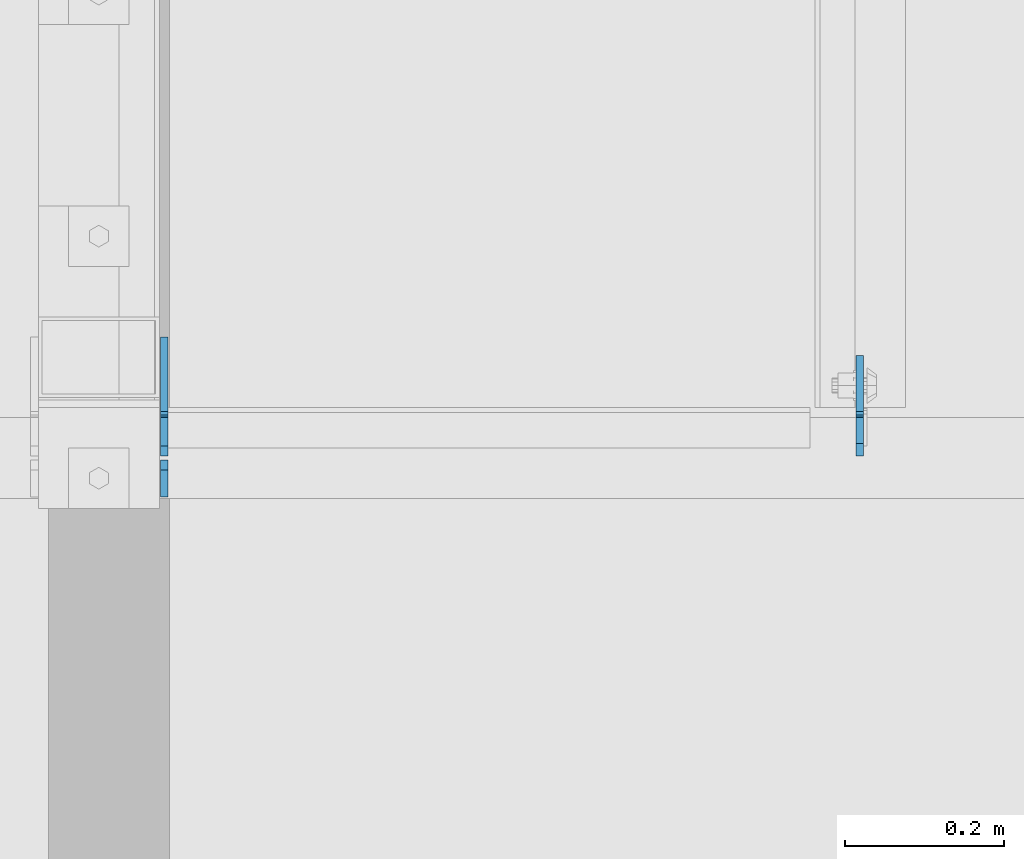
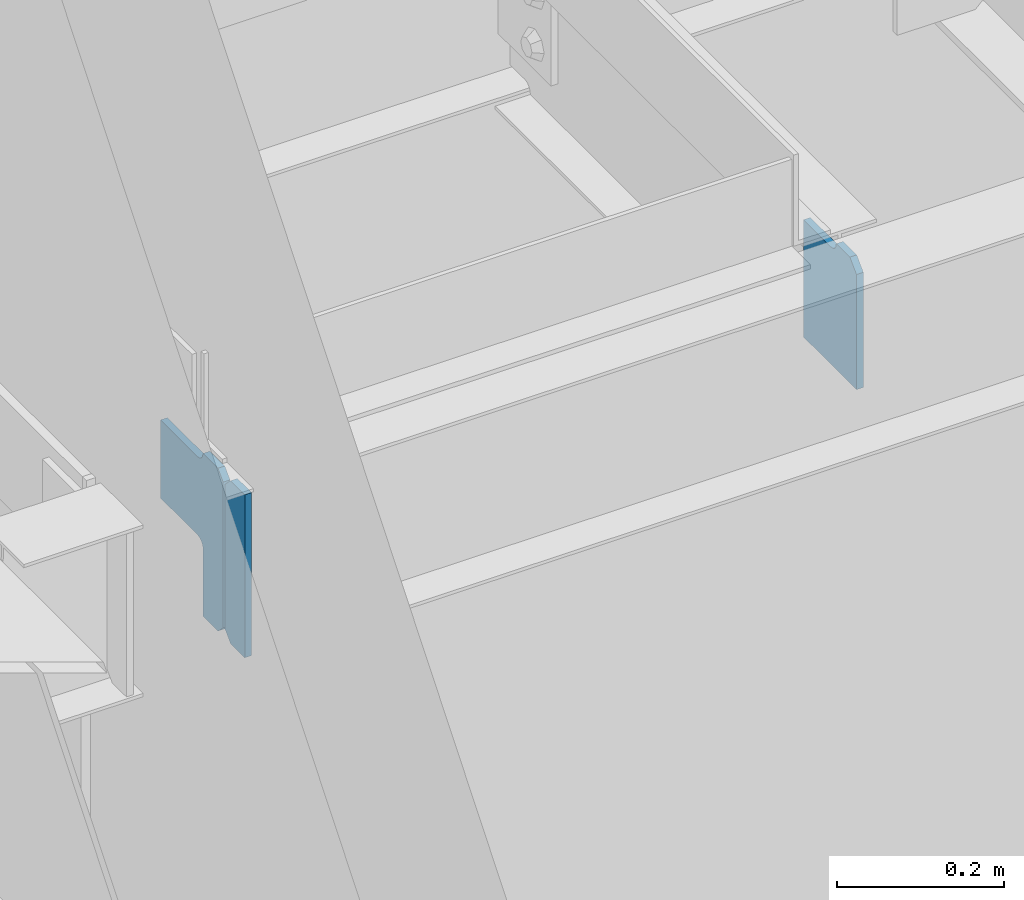
# One storey, part 1108 of 1179: 3 plates, 2 elements without a shape of their own.
"""IFC2X3 building model written with IfcOpenShell, lengths in millimetres."""

from ifc_helpers import new_model, si_unit, frame, origin_with_axes, place, context, subcontext, project, spatial, faceted_brep, material, type_object, element, aggregate, save


model = new_model("IFC2X3")

# Units and contexts
model_context = context("Model", 3, precision=1e-05, world=origin_with_axes())
body_context = subcontext(model_context, "Body", "Model", "MODEL_VIEW")
ifc_project = project(units=[si_unit("LENGTHUNIT", "METRE", prefix="MILLI"), si_unit("AREAUNIT", "SQUARE_METRE"), si_unit("VOLUMEUNIT", "CUBIC_METRE"), si_unit("MASSUNIT", "GRAM", prefix="KILO"), si_unit("TIMEUNIT", "SECOND"), si_unit("PLANEANGLEUNIT", "RADIAN"), si_unit("SOLIDANGLEUNIT", "STERADIAN"), si_unit("THERMODYNAMICTEMPERATUREUNIT", "DEGREE_CELSIUS"), si_unit("LUMINOUSINTENSITYUNIT", "LUMEN")], contexts=[model_context])

# Site, building, storey
site_placement = place(None, origin_with_axes())
site = spatial("IfcSite", under=ifc_project, at=site_placement, CompositionType="ELEMENT")
building_placement = place(site_placement, origin_with_axes())
building = spatial("IfcBuilding", under=site, at=building_placement, Name="Undefined", CompositionType="ELEMENT")
storey_placement = place(building_placement, origin_with_axes())
storey = spatial("IfcBuildingStorey", under=building, at=storey_placement, Name="Undefined", CompositionType="ELEMENT", Elevation=0.0)

# Assembly, plates
assembly_1_placement = place(storey_placement, origin_with_axes())
assembly_1 = element("IfcElementAssembly", 1, at=assembly_1_placement, inside=storey, Name="BEAM", AssemblyPlace="NOTDEFINED", PredefinedType="RIGID_FRAME")
ifc_material = material(Name="STEEL/A36")
plate_type_1 = type_object("IfcPlateType", PredefinedType="NOTDEFINED")
plate_1_placement = place(assembly_1_placement, frame((17734.7557500839, 39981.98125, 12928.6), z_axis=(0.0, 0.0, 1.0), x_axis=(0.0, 1.0, 0.0)))
plate_1 = element("IfcPlate", 2, at=plate_1_placement, type_object=plate_type_1, material=ifc_material, Name="PLATE", context=body_context, shape_type="Brep", body=[
    faceted_brep([(15.875, -4.76250000000073, 184.15), (15.875, 4.76250000000073, 184.15), (0.0, 4.76250000000073, 168.275), (0.0, -4.76250000000073, 168.275), (127.0, -4.76250000000073, 0.0), (0.0, -4.76249999999709, 0.0), (0.0, 4.76249999999709, 0.0), (127.0, 4.76250000000073, 0.0), (127.0, 4.76250000000073, 171.449999999999), (127.0, -4.76250000000073, 171.449999999999), (61.1187498092695, 4.76250000000073, 171.449999999999), (61.1187498092695, -4.76250000000073, 171.449999999999), (56.2586702912231, 4.76250000000073, 172.416729922586), (56.2586702912231, -4.76250000000073, 172.416729922586), (52.1384938230694, 4.76250000000073, 175.169743823064), (52.1384938230694, -4.76250000000073, 175.169743823064), (49.3854799225956, 4.76250000000073, 179.289920291218), (49.3854799225956, -4.76250000000073, 179.289920291218), (48.4187500000044, 4.76250000000073, 184.15), (48.4187500000044, -4.76250000000073, 184.15)], [[[0, 1, 2, 3]], [[4, 5, 6, 7]], [[4, 7, 8, 9]], [[9, 8, 10, 11]], [[11, 10, 12, 13]], [[13, 12, 14, 15]], [[15, 14, 16, 17]], [[17, 16, 18, 19]], [[5, 4, 9, 11, 13, 15, 17, 19, 0, 3]], [[6, 5, 3, 2]], [[18, 16, 14, 12, 10, 8, 7, 6, 2, 1]], [[19, 18, 1, 0]]]),
])
plate_type_2 = type_object("IfcPlateType", PredefinedType="NOTDEFINED")
plate_2_placement = place(assembly_1_placement, frame((16859.2499969376, 39930.3875, 12874.625), z_axis=(0.0, 0.0, 1.0), x_axis=(0.0, 1.0, 0.0)))
plate_2 = element("IfcPlate", 3, at=plate_2_placement, type_object=plate_type_2, material=ifc_material, Name="PLATE", context=body_context, shape_type="Brep", body=[
    faceted_brep([(0.0, -4.76249999999709, 0.0), (0.0, -4.76250000000073, 238.125), (0.0, 4.76250000000073, 238.125), (0.0, 4.76249999999709, 0.0), (34.1312501907378, -4.76250000000073, 238.125), (34.1312501907378, 4.76250000000073, 238.125), (46.8312500000029, -4.76250000000073, 225.425000190735), (46.8312500000029, 4.76250000000073, 225.425000190735), (46.8312500000029, -4.76250000000073, 12.6999998092651), (46.8312500000029, 4.76250000000073, 12.6999998092651), (34.1312501907378, -4.76250000000073, 0.0), (34.1312501907378, 4.76250000000073, 0.0)], [[[0, 1, 2, 3]], [[1, 4, 5, 2]], [[4, 6, 7, 5]], [[6, 8, 9, 7]], [[8, 10, 11, 9]], [[10, 0, 3, 11]], [[5, 7, 9, 11, 3, 2]], [[10, 8, 6, 4, 1, 0]]]),
])
aggregate(assembly_1, [plate_1, plate_2])

# Assembly, plate
assembly_2_placement = place(storey_placement, origin_with_axes())
assembly_2 = element("IfcElementAssembly", 4, at=assembly_2_placement, inside=storey, Name="PLATE", AssemblyPlace="NOTDEFINED", PredefinedType="RIGID_FRAME")
plate_type_3 = type_object("IfcPlateType", PredefinedType="NOTDEFINED")
plate_3_placement = place(assembly_2_placement, frame((16859.2499969376, 39981.9812517453, 13112.75), z_axis=(0.0, 1.0, 0.0), x_axis=(0.0, 0.0, -1.0)))
plate_3 = element("IfcPlate", 5, at=plate_3_placement, type_object=plate_type_3, material=ifc_material, Name="PLATE", context=body_context, shape_type="Brep", body=[
    faceted_brep([(4.8600797445506, -4.76249999992433, 49.3854800566332), (4.8600797445506, 4.76250000007713, 49.3854798566099), (0.00439653278954211, 4.76250000007713, 48.4187495008009), (0.004396532807732, -4.76249999992433, 48.4187497008243), (8.98025619343389, -4.76249999991705, 52.138493985949), (8.98025619343389, 4.76250000008076, 52.1384937859257), (11.7332700650695, -4.76249999990978, 56.2586704733694), (11.7332700650695, 4.76250000009168, 56.2586702733461), (12.6999999536365, -4.7624999999025, 61.1187499981825), (12.6999999536365, 4.76250000009532, 61.1187497981591), (12.6999993313366, -4.76249999976426, 150.018738193074), (12.6999993313366, 4.7625000002372, 150.018738193059), (12.6999998092651, -4.76249999999527, 1.81898940354586e-12), (0.00115318891766947, -4.7624999999789, 12.6999997569219), (0.00115318891766947, 4.76250000001892, 12.6999997569073), (12.6999998092651, 4.76250000000073, 0.0), (225.425000190735, -4.76250000000073, -6.54836185276508e-11), (225.425000190735, 4.76250000000073, -8.00355337560177e-11), (238.124999073794, -4.7624999999789, 12.6999998091924), (238.124999073794, 4.76250000001892, 12.6999998091778), (238.124996468841, -4.76249999992433, 48.418751110039), (238.124996468841, 4.76250000007713, 48.4187511100245), (139.752749147709, -4.76249999992433, 48.4187504288057), (139.752749147709, 4.76250000007713, 48.4187504287911), (134.893960414411, -4.76249999992433, 49.3849457375982), (134.893960414411, 4.76250000007713, 49.3849457375836), (130.774469166083, -4.76249999991705, 52.1365185940886), (130.774469166083, 4.7625000000844, 52.136518594074), (128.021083799133, -4.76249999990978, 56.254798617425), (128.021083799133, 4.76250000008804, 56.2547986174104), (127.052750480088, -4.7624999999025, 61.1131617072751), (127.052750480088, 4.76250000009895, 61.1131617072606), (127.013628303199, -4.76249999976062, 150.018745226909), (127.013628303199, 4.76250000024083, 150.018745226895)], [[[0, 1, 2, 3]], [[4, 5, 1, 0]], [[6, 7, 5, 4]], [[8, 9, 7, 6]], [[10, 11, 9, 8]], [[12, 13, 14, 15]], [[16, 12, 15, 17]], [[18, 16, 17, 19]], [[20, 18, 19, 21]], [[22, 20, 21, 23]], [[24, 22, 23, 25]], [[26, 24, 25, 27]], [[28, 26, 27, 29]], [[30, 28, 29, 31]], [[32, 30, 31, 33]], [[6, 4, 0, 3, 13, 12, 16, 18, 20, 22, 24, 26, 28, 30, 32, 10, 8]], [[14, 13, 3, 2]], [[33, 31, 29, 27, 25, 23, 21, 19, 17, 15, 14, 2, 1, 5, 7, 9, 11]], [[32, 33, 11, 10]]]),
])
aggregate(assembly_2, [plate_3])

save(model, "model.ifc")
